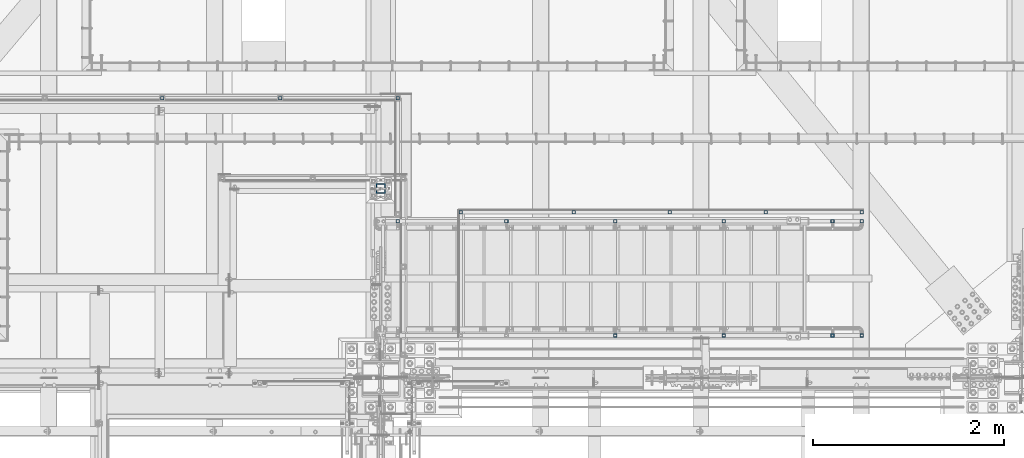
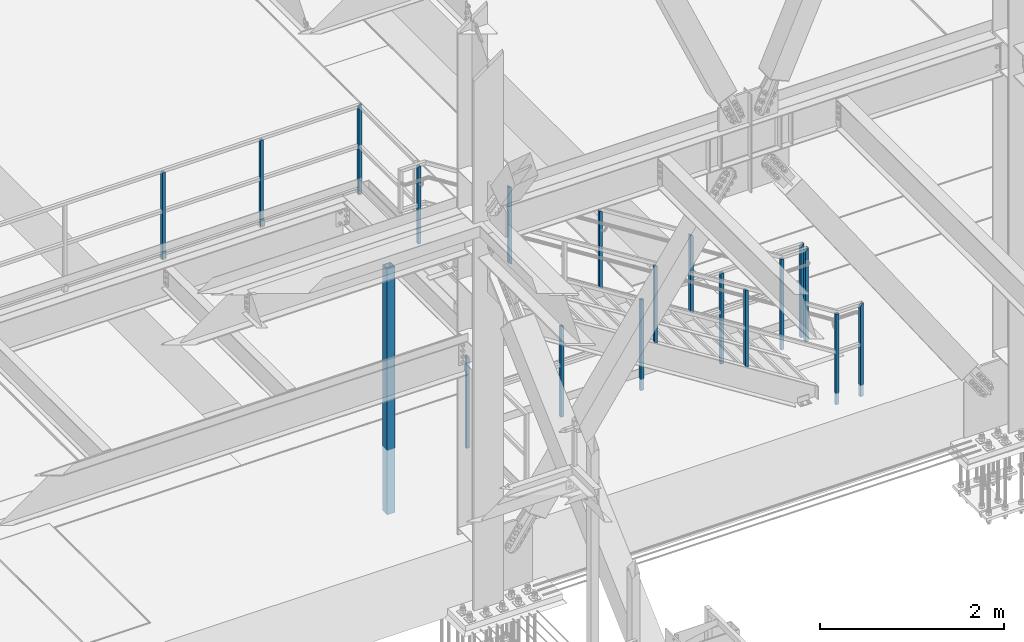
# One storey, part 1310 of 3843: 19 columns, 5 elements without a shape of their own.
"""IFC2X3 building model written with IfcOpenShell, lengths in millimetres."""

import ifcopenshell
import ifcopenshell.guid

model = None  # the IFC model being written
_history = None  # IfcOwnerHistory: only IFC2X3 demands one
_inside = {}  # id of a spatial element -> (the spatial element, [elements in it])
_under = {}  # id of a project, library or spatial element -> (it, [spatial elements below it])
_declared = {}  # id of a project -> (the project, [libraries it declares])
_typed = {}  # id of a type object -> (the type object, [elements of that type])
_made_of = {}  # id of a material, layer set ... -> (it, [elements and type objects made of it])


def new_model(schema):
    """Start an empty IFC model of exactly this schema.

    Asked for "IFC4X3", IfcOpenShell would pick the latest addendum, in which some entities
    have other attributes; the version numbers below select the first issue.
    IFC2X3 requires an IfcOwnerHistory on every rooted entity: one is made here for all.
    """
    global model, _history
    if schema == "IFC4X3":
        model = ifcopenshell.file(schema_version=(4, 3, 0, 0))
    else:
        model = ifcopenshell.file(schema=schema)
    _inside.clear()
    _under.clear()
    _declared.clear()
    _typed.clear()
    _made_of.clear()
    _history = None
    if model.schema == "IFC2X3":
        org = make("IfcOrganization", Name="unknown")
        user = make(
            "IfcPersonAndOrganization",
            ThePerson=make("IfcPerson", FamilyName="unknown"),
            TheOrganization=org,
        )
        app = make(
            "IfcApplication",
            ApplicationDeveloper=org,
            Version="unknown",
            ApplicationFullName="unknown",
            ApplicationIdentifier="unknown",
        )
        _history = make(
            "IfcOwnerHistory",
            OwningUser=user,
            OwningApplication=app,
            ChangeAction="ADDED",
            CreationDate=0,
        )
    return model


def make(cls, **values):
    """One entity of the class cls with the attributes given. An attribute that is None is left unset."""
    return model.create_entity(
        cls, **{name: value for name, value in values.items() if value is not None}
    )


def rooted(cls, **values):
    """An entity with a GlobalId (a new one), such as an element, a storey or a relation."""
    return make(cls, GlobalId=ifcopenshell.guid.new(), OwnerHistory=_history, **values)


def si_unit(unit_type, name, prefix=None):
    """IfcSIUnit, for example si_unit("LENGTHUNIT", "METRE", prefix="MILLI")."""
    return make("IfcSIUnit", UnitType=unit_type, Prefix=prefix, Name=name)


def assignment(units):
    """IfcUnitAssignment: the units of a project."""
    return None if units is None else make("IfcUnitAssignment", Units=units)


def point(xyz):
    """IfcCartesianPoint."""
    return None if xyz is None else make("IfcCartesianPoint", Coordinates=xyz)


def direction(xyz):
    """IfcDirection."""
    return None if xyz is None else make("IfcDirection", DirectionRatios=xyz)


def frame(location, z_axis=None, x_axis=None):
    """IfcAxis2Placement3D, a coordinate frame: its origin and axes. An axis left out is left unset."""
    return make(
        "IfcAxis2Placement3D",
        Location=point(location),
        Axis=direction(z_axis),
        RefDirection=direction(x_axis),
    )


def origin_with_axes():
    """The frame at (0, 0, 0) with the z axis (0, 0, 1) and the x axis (1, 0, 0) written out."""
    return frame((0.0, 0.0, 0.0), z_axis=(0.0, 0.0, 1.0), x_axis=(1.0, 0.0, 0.0))


def place(relative_to, where):
    """IfcLocalPlacement: puts the frame where relative to a parent placement (None: the world)."""
    return make(
        "IfcLocalPlacement", PlacementRelTo=relative_to, RelativePlacement=where
    )


def context(
    kind, dimensions, precision=None, world=None, true_north=None, identifier=None
):
    """IfcGeometricRepresentationContext, for example the 3D "Model" context."""
    return make(
        "IfcGeometricRepresentationContext",
        ContextIdentifier=identifier,
        ContextType=kind,
        CoordinateSpaceDimension=dimensions,
        Precision=precision,
        WorldCoordinateSystem=world,
        TrueNorth=true_north,
    )


def subcontext(parent, identifier, kind, view, scale=None):
    """IfcGeometricRepresentationSubContext, for example "Body" below "Model"."""
    return make(
        "IfcGeometricRepresentationSubContext",
        ContextIdentifier=identifier,
        ContextType=kind,
        ParentContext=parent,
        TargetScale=scale,
        TargetView=view,
    )


def project(units=None, contexts=None):
    """IfcProject with its units and contexts."""
    return rooted(
        "IfcProject",
        Name="project",
        RepresentationContexts=contexts,
        UnitsInContext=assignment(units),
    )


def spatial(cls, under=None, at=None, **own):
    """A site, building, storey or space (cls), placed at a placement, below another one or the project."""
    s = rooted(cls, ObjectPlacement=at, **own)
    if under is not None:
        _under.setdefault(under.id(), (under, []))[1].append(s)
    return s


def faces_of(points, faces, orient=None, outer=None):
    """IfcFace entities. A face is a list of loops; a loop is a list of indices into points, from 0.

    orient and outer hold one flag for each loop. By default every Orientation is true, the
    first loop of a face is its IfcFaceOuterBound and the others are IfcFaceBound.
    """
    made = []
    for i, loops in enumerate(faces):
        bounds = []
        for j, loop in enumerate(loops):
            is_outer = j == 0 if outer is None else outer[i][j]
            bounds.append(
                make(
                    "IfcFaceOuterBound" if is_outer else "IfcFaceBound",
                    Bound=make("IfcPolyLoop", Polygon=[points[k] for k in loop]),
                    Orientation=True if orient is None else orient[i][j],
                )
            )
        made.append(make("IfcFace", Bounds=bounds))
    return made


def faceted_brep(points, faces, orient=None, outer=None, voids=None):
    """IfcFacetedBrep: a solid bounded by flat faces; with voids (closed shells), ...WithVoids."""
    shared = [point(p) for p in points]
    hull = make("IfcClosedShell", CfsFaces=faces_of(shared, faces, orient, outer))
    if voids is None:
        return make("IfcFacetedBrep", Outer=hull)
    return make(
        "IfcFacetedBrepWithVoids",
        Outer=hull,
        Voids=[
            make(cls, CfsFaces=faces_of(shared, fs, o, b)) for cls, fs, o, b in voids
        ],
    )


def shape(context_of_items, identifier, shape_type, items):
    """IfcShapeRepresentation: the items that make up one representation, for example the "Body"."""
    return make(
        "IfcShapeRepresentation",
        ContextOfItems=context_of_items,
        RepresentationIdentifier=identifier,
        RepresentationType=shape_type,
        Items=items,
    )


def material(Name=None, Category=None):
    """IfcMaterial."""
    return make("IfcMaterial", Name=Name, Category=Category)


def made_of(thing, what):
    """Note that an element or type object is made of a material, layer set ...; save() writes the relation."""
    if what is not None:
        _made_of.setdefault(what.id(), (what, []))[1].append(thing)
    return thing


def type_object(cls, material=None, **own):
    """A type object (cls), such as IfcWallType, which elements share."""
    return made_of(rooted(cls, **own), material)


def element(
    cls,
    number,
    at=None,
    inside=None,
    cuts=None,
    type_object=None,
    material=None,
    context=None,
    identifier="Body",
    shape_type=None,
    held_by="IfcProductDefinitionShape",
    body=None,
    shapes=None,
    **own,
):
    """One element of the class cls, such as IfcWall. Its Tag is "e" and its number.

    at: its placement. inside: the storey or other place that contains it. cuts: it is an
    opening in that element (IfcRelVoidsElement). A single representation is given by context,
    identifier, shape_type and body (its items); several are given by shapes. held_by: the class
    of the entity that holds the representations. save() writes the other relations.
    """
    e = rooted(cls, Tag="e%d" % number, ObjectPlacement=at, **own)
    if body is not None:
        shapes = [shape(context, identifier, shape_type, body)]
    if shapes is not None:
        e.Representation = make(held_by, Representations=shapes)
    if inside is not None:
        _inside.setdefault(inside.id(), (inside, []))[1].append(e)
    if cuts is not None:
        rooted(
            "IfcRelVoidsElement", RelatingBuildingElement=cuts, RelatedOpeningElement=e
        )
    if type_object is not None:
        _typed.setdefault(type_object.id(), (type_object, []))[1].append(e)
    return made_of(e, material)


def aggregate(whole, parts):
    """IfcRelAggregates: a whole, such as a stair, and the parts it consists of."""
    return rooted("IfcRelAggregates", RelatingObject=whole, RelatedObjects=parts)


def save(model, path):
    """Write the relations noted so far, then the file.

    IfcRelAggregates (storeys below a building ...), IfcRelContainedInSpatialStructure (elements
    in a storey), IfcRelDefinesByType, IfcRelAssociatesMaterial and IfcRelDeclares: one each for
    every whole, place, type object, material and project.
    """
    for whole, parts in _under.values():
        aggregate(whole, parts)
    for where, things in _inside.values():
        rooted(
            "IfcRelContainedInSpatialStructure",
            RelatedElements=things,
            RelatingStructure=where,
        )
    for kind, things in _typed.values():
        rooted("IfcRelDefinesByType", RelatedObjects=things, RelatingType=kind)
    for what, things in _made_of.values():
        rooted("IfcRelAssociatesMaterial", RelatedObjects=things, RelatingMaterial=what)
    for by, libraries in _declared.values():
        rooted("IfcRelDeclares", RelatingContext=by, RelatedDefinitions=libraries)
    model.write(path)


model = new_model("IFC2X3")

# Units and contexts
model_context = context("Model", 3, precision=1e-05, world=origin_with_axes())
body_context = subcontext(model_context, "Body", "Model", "MODEL_VIEW")
ifc_project = project(units=[si_unit("LENGTHUNIT", "METRE", prefix="MILLI"), si_unit("AREAUNIT", "SQUARE_METRE"), si_unit("VOLUMEUNIT", "CUBIC_METRE"), si_unit("MASSUNIT", "GRAM", prefix="KILO"), si_unit("TIMEUNIT", "SECOND"), si_unit("PLANEANGLEUNIT", "RADIAN"), si_unit("SOLIDANGLEUNIT", "STERADIAN"), si_unit("THERMODYNAMICTEMPERATUREUNIT", "DEGREE_CELSIUS"), si_unit("LUMINOUSINTENSITYUNIT", "LUMEN")], contexts=[model_context])

# Site, building, storey
site_placement = place(None, origin_with_axes())
site = spatial("IfcSite", under=ifc_project, at=site_placement, CompositionType="ELEMENT")
building_placement = place(site_placement, origin_with_axes())
building = spatial("IfcBuilding", under=site, at=building_placement, Name="Undefined", CompositionType="ELEMENT")
storey_placement = place(building_placement, origin_with_axes())
storey = spatial("IfcBuildingStorey", under=building, at=storey_placement, Name="Undefined", CompositionType="ELEMENT", Elevation=0.0)

# Assembly, columns
assembly_1_placement = place(storey_placement, origin_with_axes())
assembly_1 = element("IfcElementAssembly", 1, at=assembly_1_placement, inside=storey, Name="RAIL", AssemblyPlace="NOTDEFINED", PredefinedType="RIGID_FRAME")
ifc_material_1 = material()
column_type_1 = type_object("IfcColumnType", Name="HSS1-1/2X1-1/2X1/4", PredefinedType="NOTDEFINED")
column_1_placement = place(assembly_1_placement, frame((53646.916666621, 28543.25, 33299.4000002631), z_axis=(1.0, 0.0, 0.0), x_axis=(0.0, 0.0, 1.0)))
column_1 = element("IfcColumn", 2, at=column_1_placement, type_object=column_type_1, material=ifc_material_1, Name="POST", ObjectType="HSS1-1/2X1-1/2X1/4", context=body_context, shape_type="Brep", body=[
    faceted_brep([(-88.8999998754371, 12.6999993300014, -12.6999993299978), (-88.8999998754371, -12.6999993300014, -12.6999993299978), (1047.75000076497, -12.6999993300014, -12.6999993299978), (1047.75000076497, 12.6999993300014, -12.6999993299978), (-88.8999998754371, -12.6999993300014, 12.6999993299978), (1047.75000076497, -12.6999993300014, 12.6999993299978), (-88.8999998754371, 12.6999993300014, 12.6999993299978), (1047.75000076497, 12.6999993300014, 12.6999993299978), (-88.8999998754371, 19.0499992350015, -19.0499992350015), (-88.8999998754371, 19.0499992350015, 19.0499992350015), (1047.75000076629, 19.0499992350015, 19.0499992349942), (1047.750000765, 19.0499992350015, -19.0499992350015), (-88.8999998754371, -19.0499992350015, 19.0499992350015), (1047.75000076629, -19.0499992350015, 19.0499992349942), (-88.8999998754371, -19.0499992350015, -19.0499992350015), (1047.750000765, -19.0499992350015, -19.0499992350015)], [[[0, 1, 2, 3]], [[1, 4, 5, 2]], [[4, 6, 7, 5]], [[6, 0, 3, 7]], [[8, 9, 10, 11]], [[9, 12, 13, 10]], [[12, 14, 15, 13]], [[14, 8, 11, 15]], [[13, 15, 11, 10], [5, 7, 3, 2]], [[14, 12, 9, 8], [6, 4, 1, 0]]]),
])
column_2_placement = place(assembly_1_placement, frame((54877.7583332823, 28543.25, 33299.4000002631), z_axis=(1.0, 0.0, 0.0), x_axis=(0.0, 0.0, 1.0)))
column_2 = element("IfcColumn", 3, at=column_2_placement, type_object=column_type_1, material=ifc_material_1, Name="POST", ObjectType="HSS1-1/2X1-1/2X1/4", context=body_context, shape_type="Brep", body=[
    faceted_brep([(-88.8999998754371, 12.6999993300014, -12.6999993299978), (-88.8999998754371, -12.6999993300014, -12.6999993299978), (1047.75000076497, -12.6999993300014, -12.6999993299978), (1047.75000076497, 12.6999993300014, -12.6999993299978), (-88.8999998754371, -12.6999993300014, 12.6999993299978), (1047.75000076497, -12.6999993300014, 12.6999993299978), (-88.8999998754371, 12.6999993300014, 12.6999993299978), (1047.75000076497, 12.6999993300014, 12.6999993299978), (-88.8999998754371, 19.0499992350015, -19.0499992350015), (-88.8999998754371, 19.0499992350015, 19.0499992350015), (1047.75000076629, 19.0499992350015, 19.0499992349942), (1047.750000765, 19.0499992350015, -19.0499992350015), (-88.8999998754371, -19.0499992350015, 19.0499992350015), (1047.75000076629, -19.0499992350015, 19.0499992349942), (-88.8999998754371, -19.0499992350015, -19.0499992350015), (1047.750000765, -19.0499992350015, -19.0499992350015)], [[[0, 1, 2, 3]], [[1, 4, 5, 2]], [[4, 6, 7, 5]], [[6, 0, 3, 7]], [[8, 9, 10, 11]], [[9, 12, 13, 10]], [[12, 14, 15, 13]], [[14, 8, 11, 15]], [[13, 15, 11, 10], [5, 7, 3, 2]], [[14, 12, 9, 8], [6, 4, 1, 0]]]),
])
column_3_placement = place(assembly_1_placement, frame((56108.5999999435, 28543.25, 33299.4000002631), z_axis=(1.0, 0.0, 0.0), x_axis=(0.0, 0.0, 1.0)))
column_3 = element("IfcColumn", 4, at=column_3_placement, type_object=column_type_1, material=ifc_material_1, Name="POST", ObjectType="HSS1-1/2X1-1/2X1/4", context=body_context, shape_type="Brep", body=[
    faceted_brep([(-88.8999998754371, 12.6999993300014, -12.6999993299978), (-88.8999998754371, -12.6999993300014, -12.6999993299978), (1054.10000067001, -12.6999993300014, -12.6999993299978), (1054.10000067001, 12.6999993300014, -12.6999993299978), (-88.8999998754371, -12.6999993300014, 12.6999993299978), (1079.49999933, -12.6999993300014, 12.6999993299978), (-88.8999998754371, 12.6999993300014, 12.6999993299978), (1079.49999933, 12.6999993300014, 12.6999993299978), (-88.8999998754371, 19.0499992350015, -19.0499992350015), (-88.8999998754371, 19.0499992350015, 19.0499992350015), (1085.849999235, 19.0499992350015, 19.0499992350015), (1047.750000765, 19.0499992350015, -19.0499992350015), (-88.8999998754371, -19.0499992350015, 19.0499992350015), (1085.849999235, -19.0499992350015, 19.0499992350015), (-88.8999998754371, -19.0499992350015, -19.0499992350015), (1047.750000765, -19.0499992350015, -19.0499992350015)], [[[0, 1, 2, 3]], [[1, 4, 5, 2]], [[4, 6, 7, 5]], [[6, 0, 3, 7]], [[8, 9, 10, 11]], [[9, 12, 13, 10]], [[12, 14, 15, 13]], [[14, 8, 11, 15]], [[13, 15, 11, 10], [5, 7, 3, 2]], [[14, 12, 9, 8], [6, 4, 1, 0]]]),
])
aggregate(assembly_1, [column_1, column_2, column_3])

assembly_2_placement = place(storey_placement, origin_with_axes())
assembly_2 = element("IfcElementAssembly", 5, at=assembly_2_placement, inside=storey, Name="RAIL", AssemblyPlace="NOTDEFINED", PredefinedType="RIGID_FRAME")
column_4_placement = place(assembly_2_placement, frame((59956.6999999969, 27349.45000005, 30479.9999999739), z_axis=(1.0, 0.0, 0.0), x_axis=(0.0, 0.0, 1.0)))
column_4 = element("IfcColumn", 6, at=column_4_placement, type_object=column_type_1, material=ifc_material_1, Name="POST", ObjectType="HSS1-1/2X1-1/2X1/4", context=body_context, shape_type="Brep", body=[
    faceted_brep([(-152.399999977541, 12.6999993299978, -12.6999993299978), (-152.399999977541, -12.6999993299978, -12.6999993299978), (1047.75000076497, -12.6999993300014, -12.6999993299978), (1047.75000076497, 12.6999993300014, -12.6999993299978), (-152.399999977541, -12.6999993299978, 12.6999993299978), (1047.75000076497, -12.6999993300014, 12.6999993299978), (-152.399999977541, 12.6999993299978, 12.6999993299978), (1047.75000076497, 12.6999993300014, 12.6999993299978), (-152.399999977541, 19.0499992350015, -19.0499992349942), (-152.399999977541, 19.0499992350015, 19.0499992349942), (1047.75000076629, 19.0499992350015, 19.0499992349942), (1047.750000765, 19.0499992350015, -19.0499992350015), (-152.399999977541, -19.0499992350015, 19.0499992349942), (1047.75000076629, -19.0499992350015, 19.0499992349942), (-152.399999977541, -19.0499992350015, -19.0499992349942), (1047.750000765, -19.0499992350015, -19.0499992350015)], [[[0, 1, 2, 3]], [[1, 4, 5, 2]], [[4, 6, 7, 5]], [[6, 0, 3, 7]], [[8, 9, 10, 11]], [[9, 12, 13, 10]], [[12, 14, 15, 13]], [[14, 8, 11, 15]], [[13, 15, 11, 10], [5, 7, 3, 2]], [[14, 12, 9, 8], [6, 4, 1, 0]]]),
])
column_5_placement = place(assembly_2_placement, frame((57950.1000000012, 27349.45000005, 30479.9999999739), z_axis=(1.0, 0.0, 0.0), x_axis=(0.0, 0.0, 1.0)))
column_5 = element("IfcColumn", 7, at=column_5_placement, type_object=column_type_1, material=ifc_material_1, Name="POST", ObjectType="HSS1-1/2X1-1/2X1/4", context=body_context, shape_type="Brep", body=[
    faceted_brep([(-152.399999977541, 12.6999993299978, -12.6999993299978), (-152.399999977541, -12.6999993299978, -12.6999993299978), (1047.75000076497, -12.6999993300014, -12.6999993299978), (1047.75000076497, 12.6999993300014, -12.6999993299978), (-152.399999977541, -12.6999993299978, 12.6999993299978), (1047.75000076497, -12.6999993300014, 12.6999993299978), (-152.399999977541, 12.6999993299978, 12.6999993299978), (1047.75000076497, 12.6999993300014, 12.6999993299978), (-152.399999977541, 19.0499992350015, -19.0499992349942), (-152.399999977541, 19.0499992350015, 19.0499992349942), (1047.75000076629, 19.0499992350015, 19.0499992349942), (1047.750000765, 19.0499992350015, -19.0499992350015), (-152.399999977541, -19.0499992350015, 19.0499992349942), (1047.75000076629, -19.0499992350015, 19.0499992349942), (-152.399999977541, -19.0499992350015, -19.0499992349942), (1047.750000765, -19.0499992350015, -19.0499992350015)], [[[0, 1, 2, 3]], [[1, 4, 5, 2]], [[4, 6, 7, 5]], [[6, 0, 3, 7]], [[8, 9, 10, 11]], [[9, 12, 13, 10]], [[12, 14, 15, 13]], [[14, 8, 11, 15]], [[13, 15, 11, 10], [5, 7, 3, 2]], [[14, 12, 9, 8], [6, 4, 1, 0]]]),
])
column_6_placement = place(assembly_2_placement, frame((58953.399999999, 27349.45000005, 30479.9999999739), z_axis=(1.0, 0.0, 0.0), x_axis=(0.0, 0.0, 1.0)))
column_6 = element("IfcColumn", 8, at=column_6_placement, type_object=column_type_1, material=ifc_material_1, Name="POST", ObjectType="HSS1-1/2X1-1/2X1/4", context=body_context, shape_type="Brep", body=[
    faceted_brep([(-152.399999977541, 12.6999993299978, -12.6999993299978), (-152.399999977541, -12.6999993299978, -12.6999993299978), (1047.75000076497, -12.6999993300014, -12.6999993299978), (1047.75000076497, 12.6999993300014, -12.6999993299978), (-152.399999977541, -12.6999993299978, 12.6999993299978), (1047.75000076497, -12.6999993300014, 12.6999993299978), (-152.399999977541, 12.6999993299978, 12.6999993299978), (1047.75000076497, 12.6999993300014, 12.6999993299978), (-152.399999977541, 19.0499992350015, -19.0499992349942), (-152.399999977541, 19.0499992350015, 19.0499992349942), (1047.75000076629, 19.0499992350015, 19.0499992349942), (1047.750000765, 19.0499992350015, -19.0499992350015), (-152.399999977541, -19.0499992350015, 19.0499992349942), (1047.75000076629, -19.0499992350015, 19.0499992349942), (-152.399999977541, -19.0499992350015, -19.0499992349942), (1047.750000765, -19.0499992350015, -19.0499992350015)], [[[0, 1, 2, 3]], [[1, 4, 5, 2]], [[4, 6, 7, 5]], [[6, 0, 3, 7]], [[8, 9, 10, 11]], [[9, 12, 13, 10]], [[12, 14, 15, 13]], [[14, 8, 11, 15]], [[13, 15, 11, 10], [5, 7, 3, 2]], [[14, 12, 9, 8], [6, 4, 1, 0]]]),
])
column_7_placement = place(assembly_2_placement, frame((56769.0000000085, 27349.45000005, 30479.9999999739), z_axis=(1.0, 0.0, 0.0), x_axis=(0.0, 0.0, 1.0)))
column_7 = element("IfcColumn", 9, at=column_7_placement, type_object=column_type_1, material=ifc_material_1, Name="POST", ObjectType="HSS1-1/2X1-1/2X1/4", context=body_context, shape_type="Brep", body=[
    faceted_brep([(-152.399999977541, 12.6999993299978, -12.6999993299978), (-152.399999977541, -12.6999993299978, -12.6999993299978), (1079.49999933128, -12.6999993300014, -12.6999993299978), (1079.49999933128, 12.6999993300014, -12.6999993299978), (-152.399999977541, -12.6999993299978, 12.6999993299978), (1054.10000067129, -12.6999993300014, 12.6999993299978), (-152.399999977541, 12.6999993299978, 12.6999993299978), (1054.10000067129, 12.6999993300014, 12.6999993299978), (-152.399999977541, 19.0499992350015, -19.0499992349942), (-152.399999977541, 19.0499992350015, 19.0499992349942), (1047.75000076629, 19.0499992350015, 19.0499992349942), (1085.84999923629, 19.0499992350015, -19.0499992349942), (-152.399999977541, -19.0499992350015, 19.0499992349942), (1047.75000076629, -19.0499992350015, 19.0499992349942), (-152.399999977541, -19.0499992350015, -19.0499992349942), (1085.84999923629, -19.0499992350015, -19.0499992349942)], [[[0, 1, 2, 3]], [[1, 4, 5, 2]], [[4, 6, 7, 5]], [[6, 0, 3, 7]], [[8, 9, 10, 11]], [[9, 12, 13, 10]], [[12, 14, 15, 13]], [[14, 8, 11, 15]], [[13, 15, 11, 10], [5, 7, 3, 2]], [[14, 12, 9, 8], [6, 4, 1, 0]]]),
])
column_8_placement = place(assembly_2_placement, frame((60959.9999999948, 27349.45000005, 30479.9999999739), z_axis=(1.0, 0.0, 0.0), x_axis=(0.0, 0.0, 1.0)))
column_8 = element("IfcColumn", 10, at=column_8_placement, type_object=column_type_1, material=ifc_material_1, Name="POST", ObjectType="HSS1-1/2X1-1/2X1/4", context=body_context, shape_type="Brep", body=[
    faceted_brep([(-152.399999977541, 12.6999993299978, -12.6999993299978), (-152.399999977541, -12.6999993299978, -12.6999993299978), (1054.10000067001, -12.6999993300014, -12.6999993299978), (1054.10000067001, 12.6999993300014, -12.6999993299978), (-152.399999977541, -12.6999993299978, 12.6999993299978), (1079.49999933, -12.6999993300014, 12.6999993299978), (-152.399999977541, 12.6999993299978, 12.6999993299978), (1079.49999933, 12.6999993300014, 12.6999993299978), (-152.399999977541, 19.0499992350015, -19.0499992349942), (-152.399999977541, 19.0499992350015, 19.0499992349942), (1085.849999235, 19.0499992350015, 19.0499992350015), (1047.750000765, 19.0499992350015, -19.0499992350015), (-152.399999977541, -19.0499992350015, 19.0499992349942), (1085.849999235, -19.0499992350015, 19.0499992350015), (-152.399999977541, -19.0499992350015, -19.0499992349942), (1047.750000765, -19.0499992350015, -19.0499992350015)], [[[0, 1, 2, 3]], [[1, 4, 5, 2]], [[4, 6, 7, 5]], [[6, 0, 3, 7]], [[8, 9, 10, 11]], [[9, 12, 13, 10]], [[12, 14, 15, 13]], [[14, 8, 11, 15]], [[13, 15, 11, 10], [5, 7, 3, 2]], [[14, 12, 9, 8], [6, 4, 1, 0]]]),
])
aggregate(assembly_2, [column_4, column_5, column_6, column_7, column_8])

assembly_3_placement = place(storey_placement, origin_with_axes())
assembly_3 = element("IfcElementAssembly", 11, at=assembly_3_placement, inside=storey, Name="RAIL", AssemblyPlace="NOTDEFINED", PredefinedType="RIGID_FRAME")
column_9_placement = place(assembly_3_placement, frame((56108.5999999435, 27254.20000005, 33299.4000002631), z_axis=(1.0, 0.0, 0.0), x_axis=(0.0, 0.0, 1.0)))
column_9 = element("IfcColumn", 12, at=column_9_placement, type_object=column_type_1, material=ifc_material_1, Name="POST", ObjectType="HSS1-1/2X1-1/2X1/4", context=body_context, shape_type="Brep", body=[
    faceted_brep([(1047.75000076629, -19.0499992350015, 19.0499992349942), (1047.750000765, -19.0499992350015, -19.0499992350015), (1047.750000765, 19.0499992350015, -19.0499992350015), (1047.75000076629, 19.0499992350015, 19.0499992349942), (1047.75000076497, -12.6999993300014, 12.6999993299978), (1047.75000076497, 12.6999993300014, 12.6999993299978), (1047.75000076497, 12.6999993300014, -12.6999993299978), (1047.75000076497, -12.6999993300014, -12.6999993299978), (25.4000000135893, 19.0499992350015, -19.0499992349942), (25.4000000135893, 19.0499992350015, 19.0499992349942), (25.4000000135893, -19.0499992350015, -19.0499992349942), (25.4000000135893, -19.0499992350015, 19.0499992349942), (25.4000000135893, 12.6999993300014, -12.6999993299978), (25.4000000135893, 12.6999993300014, 12.6999993299978), (25.4000000135893, -12.6999993300014, 12.6999993299978), (25.4000000135893, -12.6999993300014, -12.6999993299978)], [[[0, 1, 2, 3], [4, 5, 6, 7]], [[3, 2, 8, 9]], [[2, 1, 10, 8]], [[1, 0, 11, 10]], [[0, 3, 9, 11]], [[8, 10, 11, 9], [12, 13, 14, 15]], [[4, 7, 15, 14]], [[7, 6, 12, 15]], [[6, 5, 13, 12]], [[5, 4, 14, 13]]]),
])
column_10_placement = place(assembly_3_placement, frame((57245.2499999552, 27254.20000005, 32660.6230938254), z_axis=(1.0, 0.0, 0.0), x_axis=(0.0, 0.0, 1.0)))
column_10 = element("IfcColumn", 13, at=column_10_placement, type_object=column_type_1, material=ifc_material_1, Name="POST", ObjectType="HSS1-1/2X1-1/2X1/4", context=body_context, shape_type="Brep", body=[
    faceted_brep([(8.00965862412704, 12.6999993300014, -12.6999993299978), (8.00965862412704, -12.6999993300014, -12.6999993299978), (1022.25781065416, -12.6999993300014, -12.6999993299978), (1022.25781065416, 12.6999993300014, -12.6999993299978), (-8.00965871479639, -12.6999993300014, 12.6999993299978), (1006.23849331524, -12.6999993300014, 12.6999993299978), (-8.00965871479639, 12.6999993300014, 12.6999993299978), (1006.23849331524, 12.6999993300014, 12.6999993299978), (12.0144881102206, 19.0499992350015, -19.0499992350015), (-12.0144882008899, 19.0499992350015, 19.0499992350015), (1002.23366382914, 19.0499992350015, 19.0499992350015), (1026.26264014026, 19.0499992350015, -19.0499992350015), (-12.0144882008899, -19.0499992350015, 19.0499992350015), (1002.23366382914, -19.0499992350015, 19.0499992350015), (12.0144881102206, -19.0499992350015, -19.0499992350015), (1026.26264014026, -19.0499992350015, -19.0499992350015)], [[[0, 1, 2, 3]], [[1, 4, 5, 2]], [[4, 6, 7, 5]], [[6, 0, 3, 7]], [[8, 9, 10, 11]], [[9, 12, 13, 10]], [[12, 14, 15, 13]], [[14, 8, 11, 15]], [[13, 15, 11, 10], [5, 7, 3, 2]], [[14, 12, 9, 8], [6, 4, 1, 0]]]),
])
column_11_placement = place(assembly_3_placement, frame((58381.8999999682, 27254.20000005, 31943.7586050649), z_axis=(1.0, 0.0, 0.0), x_axis=(0.0, 0.0, 1.0)))
column_11 = element("IfcColumn", 14, at=column_11_placement, type_object=column_type_1, material=ifc_material_1, Name="POST", ObjectType="HSS1-1/2X1-1/2X1/4", context=body_context, shape_type="Brep", body=[
    faceted_brep([(8.00965862412704, 12.6999993300014, -12.6999993299978), (8.00965862412704, -12.6999993300014, -12.6999993299978), (1022.25781065416, -12.6999993300014, -12.6999993299978), (1022.25781065416, 12.6999993300014, -12.6999993299978), (-8.00965871479639, -12.6999993300014, 12.6999993299978), (1006.23849331524, -12.6999993300014, 12.6999993299978), (-8.00965871479639, 12.6999993300014, 12.6999993299978), (1006.23849331524, 12.6999993300014, 12.6999993299978), (12.0144881102206, 19.0499992350015, -19.0499992350015), (-12.0144882008899, 19.0499992350015, 19.0499992350015), (1002.23366382914, 19.0499992350015, 19.0499992350015), (1026.26264014026, 19.0499992350015, -19.0499992350015), (-12.0144882008899, -19.0499992350015, 19.0499992350015), (1002.23366382914, -19.0499992350015, 19.0499992350015), (12.0144881102206, -19.0499992350015, -19.0499992350015), (1026.26264014026, -19.0499992350015, -19.0499992350015)], [[[0, 1, 2, 3]], [[1, 4, 5, 2]], [[4, 6, 7, 5]], [[6, 0, 3, 7]], [[8, 9, 10, 11]], [[9, 12, 13, 10]], [[12, 14, 15, 13]], [[14, 8, 11, 15]], [[13, 15, 11, 10], [5, 7, 3, 2]], [[14, 12, 9, 8], [6, 4, 1, 0]]]),
])
column_12_placement = place(assembly_3_placement, frame((59518.5499999813, 27254.20000005, 31226.8941163045), z_axis=(1.0, 0.0, 0.0), x_axis=(0.0, 0.0, 1.0)))
column_12 = element("IfcColumn", 15, at=column_12_placement, type_object=column_type_1, material=ifc_material_1, Name="POST", ObjectType="HSS1-1/2X1-1/2X1/4", context=body_context, shape_type="Brep", body=[
    faceted_brep([(8.00965862412704, 12.6999993300014, -12.6999993299978), (8.00965862412704, -12.6999993300014, -12.6999993299978), (1022.25781065416, -12.6999993300014, -12.6999993299978), (1022.25781065416, 12.6999993300014, -12.6999993299978), (-8.00965871479639, -12.6999993300014, 12.6999993299978), (1006.23849331524, -12.6999993300014, 12.6999993299978), (-8.00965871479639, 12.6999993300014, 12.6999993299978), (1006.23849331524, 12.6999993300014, 12.6999993299978), (12.0144881102206, 19.0499992350015, -19.0499992350015), (-12.0144882008899, 19.0499992350015, 19.0499992350015), (1002.23366382914, 19.0499992350015, 19.0499992350015), (1026.26264014026, 19.0499992350015, -19.0499992350015), (-12.0144882008899, -19.0499992350015, 19.0499992350015), (1002.23366382914, -19.0499992350015, 19.0499992350015), (12.0144881102206, -19.0499992350015, -19.0499992350015), (1026.26264014026, -19.0499992350015, -19.0499992350015)], [[[0, 1, 2, 3]], [[1, 4, 5, 2]], [[4, 6, 7, 5]], [[6, 0, 3, 7]], [[8, 9, 10, 11]], [[9, 12, 13, 10]], [[12, 14, 15, 13]], [[14, 8, 11, 15]], [[13, 15, 11, 10], [5, 7, 3, 2]], [[14, 12, 9, 8], [6, 4, 1, 0]]]),
])
column_13_placement = place(assembly_3_placement, frame((60655.1999999948, 27254.20000005, 30479.9999999806), z_axis=(1.0, 0.0, 0.0), x_axis=(0.0, 0.0, 1.0)))
column_13 = element("IfcColumn", 16, at=column_13_placement, type_object=column_type_1, material=ifc_material_1, Name="POST", ObjectType="HSS1-1/2X1-1/2X1/4", context=body_context, shape_type="Brep", body=[
    faceted_brep([(1047.75000076629, -19.0499992350015, 19.0499992349942), (1047.7500007748, -19.0499992349978, -5.50550330031547), (1047.7500007748, -12.6999993300014, -5.50550330031547), (1047.75000076497, -12.6999993300014, 12.6999993299978), (1047.75000076497, 12.6999993300014, 12.6999993299978), (1047.7500007748, 12.6999993300014, -5.50550330031547), (1047.7500007748, 19.0499992350015, -5.50550330031547), (1047.75000076629, 19.0499992350015, 19.0499992349942), (1056.29226809751, -19.0499992350015, -19.0499992350015), (1056.29226809751, 19.0499992350015, -19.0499992350015), (1052.28743861182, 12.6999993300014, -12.6999993299978), (1052.28743861182, -12.6999993300014, -12.6999993299978), (-152.399999977541, 19.0499992350015, 19.0499992349942), (-152.399999977541, -19.0499992350015, 19.0499992349942), (-152.399999977541, -19.0499992350015, -19.0499992349942), (-152.399999977541, 19.0499992350015, -19.0499992349942), (-152.399999977541, 12.6999993299978, 12.6999993299978), (-152.399999977541, -12.6999993299978, 12.6999993299978), (-152.399999977541, -12.6999993299978, -12.6999993299978), (-152.399999977541, 12.6999993299978, -12.6999993299978)], [[[0, 1, 2, 3, 4, 5, 6, 7]], [[8, 9, 6, 5, 10, 11, 2, 1]], [[12, 13, 0, 7]], [[0, 13, 14, 8, 1]], [[14, 15, 9, 8]], [[15, 12, 7, 6, 9]], [[14, 13, 12, 15], [16, 17, 18, 19]], [[19, 18, 11, 10]], [[4, 16, 19, 10, 5]], [[17, 16, 4, 3]], [[18, 17, 3, 2, 11]]]),
])
column_14_placement = place(assembly_3_placement, frame((60959.9999999948, 27254.20000005, 30479.9999999739), z_axis=(1.0, 0.0, 0.0), x_axis=(0.0, 0.0, 1.0)))
column_14 = element("IfcColumn", 17, at=column_14_placement, type_object=column_type_1, material=ifc_material_1, Name="POST", ObjectType="HSS1-1/2X1-1/2X1/4", context=body_context, shape_type="Brep", body=[
    faceted_brep([(-152.399999977541, 12.6999993299978, -12.6999993299978), (-152.399999977541, -12.6999993299978, -12.6999993299978), (1054.10000067001, -12.6999993300014, -12.6999993299978), (1054.10000067001, 12.6999993300014, -12.6999993299978), (-152.399999977541, -12.6999993299978, 12.6999993299978), (1079.49999933, -12.6999993300014, 12.6999993299978), (-152.399999977541, 12.6999993299978, 12.6999993299978), (1079.49999933, 12.6999993300014, 12.6999993299978), (-152.399999977541, 19.0499992350015, -19.0499992349942), (-152.399999977541, 19.0499992350015, 19.0499992349942), (1085.849999235, 19.0499992350015, 19.0499992350015), (1047.750000765, 19.0499992350015, -19.0499992350015), (-152.399999977541, -19.0499992350015, 19.0499992349942), (1085.849999235, -19.0499992350015, 19.0499992350015), (-152.399999977541, -19.0499992350015, -19.0499992349942), (1047.750000765, -19.0499992350015, -19.0499992350015)], [[[0, 1, 2, 3]], [[1, 4, 5, 2]], [[4, 6, 7, 5]], [[6, 0, 3, 7]], [[8, 9, 10, 11]], [[9, 12, 13, 10]], [[12, 14, 15, 13]], [[14, 8, 11, 15]], [[13, 15, 11, 10], [5, 7, 3, 2]], [[14, 12, 9, 8], [6, 4, 1, 0]]]),
])
aggregate(assembly_3, [column_9, column_10, column_11, column_12, column_13, column_14])

assembly_4_placement = place(storey_placement, origin_with_axes())
assembly_4 = element("IfcElementAssembly", 18, at=assembly_4_placement, inside=storey, Name="RAIL", AssemblyPlace="NOTDEFINED", PredefinedType="RIGID_FRAME")
column_15_placement = place(assembly_4_placement, frame((58381.8999999634, 26060.40000005, 31943.7586050722), z_axis=(1.0, 0.0, 0.0), x_axis=(0.0, 0.0, 1.0)))
column_15 = element("IfcColumn", 19, at=column_15_placement, type_object=column_type_1, material=ifc_material_1, Name="POST", ObjectType="HSS1-1/2X1-1/2X1/4", context=body_context, shape_type="Brep", body=[
    faceted_brep([(8.00965862412704, 12.6999993300014, -12.6999993299978), (8.00965862412704, -12.6999993300014, -12.6999993299978), (1022.25781065416, -12.6999993300014, -12.6999993299978), (1022.25781065416, 12.6999993300014, -12.6999993299978), (-8.00965871479639, -12.6999993300014, 12.6999993299978), (1006.23849331524, -12.6999993300014, 12.6999993299978), (-8.00965871479639, 12.6999993300014, 12.6999993299978), (1006.23849331524, 12.6999993300014, 12.6999993299978), (12.0144881102206, 19.0499992350015, -19.0499992350015), (-12.0144882008899, 19.0499992350015, 19.0499992350015), (1002.23366382914, 19.0499992350015, 19.0499992350015), (1026.26264014026, 19.0499992350015, -19.0499992350015), (-12.0144882008899, -19.0499992350015, 19.0499992350015), (1002.23366382914, -19.0499992350015, 19.0499992350015), (12.0144881102206, -19.0499992350015, -19.0499992350015), (1026.26264014026, -19.0499992350015, -19.0499992350015)], [[[0, 1, 2, 3]], [[1, 4, 5, 2]], [[4, 6, 7, 5]], [[6, 0, 3, 7]], [[8, 9, 10, 11]], [[9, 12, 13, 10]], [[12, 14, 15, 13]], [[14, 8, 11, 15]], [[13, 15, 11, 10], [5, 7, 3, 2]], [[14, 12, 9, 8], [6, 4, 1, 0]]]),
])
column_16_placement = place(assembly_4_placement, frame((59518.5499999791, 26060.40000005, 31226.8941163076), z_axis=(1.0, 0.0, 0.0), x_axis=(0.0, 0.0, 1.0)))
column_16 = element("IfcColumn", 20, at=column_16_placement, type_object=column_type_1, material=ifc_material_1, Name="POST", ObjectType="HSS1-1/2X1-1/2X1/4", context=body_context, shape_type="Brep", body=[
    faceted_brep([(8.00965862412704, 12.6999993300014, -12.6999993299978), (8.00965862412704, -12.6999993300014, -12.6999993299978), (1022.25781065416, -12.6999993300014, -12.6999993299978), (1022.25781065416, 12.6999993300014, -12.6999993299978), (-8.00965871479639, -12.6999993300014, 12.6999993299978), (1006.23849331524, -12.6999993300014, 12.6999993299978), (-8.00965871479639, 12.6999993300014, 12.6999993299978), (1006.23849331524, 12.6999993300014, 12.6999993299978), (12.0144881102206, 19.0499992350015, -19.0499992350015), (-12.0144882008899, 19.0499992350015, 19.0499992350015), (1002.23366382914, 19.0499992350015, 19.0499992350015), (1026.26264014026, 19.0499992350015, -19.0499992350015), (-12.0144882008899, -19.0499992350015, 19.0499992350015), (1002.23366382914, -19.0499992350015, 19.0499992350015), (12.0144881102206, -19.0499992350015, -19.0499992350015), (1026.26264014026, -19.0499992350015, -19.0499992350015)], [[[0, 1, 2, 3]], [[1, 4, 5, 2]], [[4, 6, 7, 5]], [[6, 0, 3, 7]], [[8, 9, 10, 11]], [[9, 12, 13, 10]], [[12, 14, 15, 13]], [[14, 8, 11, 15]], [[13, 15, 11, 10], [5, 7, 3, 2]], [[14, 12, 9, 8], [6, 4, 1, 0]]]),
])
column_17_placement = place(assembly_4_placement, frame((60655.1999999967, 26060.40000005, 30479.9999999775), z_axis=(1.0, 0.0, 0.0), x_axis=(0.0, 0.0, 1.0)))
column_17 = element("IfcColumn", 21, at=column_17_placement, type_object=column_type_1, material=ifc_material_1, Name="POST", ObjectType="HSS1-1/2X1-1/2X1/4", context=body_context, shape_type="Brep", body=[
    faceted_brep([(1047.75000076629, -19.0499992350015, 19.0499992349942), (1047.7500007748, -19.0499992349978, -5.50550330031547), (1047.7500007748, -12.6999993300014, -5.50550330031547), (1047.75000076497, -12.6999993300014, 12.6999993299978), (1047.75000076497, 12.6999993300014, 12.6999993299978), (1047.7500007748, 12.6999993300014, -5.50550330031547), (1047.7500007748, 19.0499992350015, -5.50550330031547), (1047.75000076629, 19.0499992350015, 19.0499992349942), (1056.29226809751, -19.0499992350015, -19.0499992350015), (1056.29226809751, 19.0499992350015, -19.0499992350015), (1052.28743861182, 12.6999993300014, -12.6999993299978), (1052.28743861182, -12.6999993300014, -12.6999993299978), (-152.399999977541, 19.0499992350015, 19.0499992349942), (-152.399999977541, -19.0499992350015, 19.0499992349942), (-152.399999977541, -19.0499992350015, -19.0499992349942), (-152.399999977541, 19.0499992350015, -19.0499992349942), (-152.399999977541, 12.6999993299978, 12.6999993299978), (-152.399999977541, -12.6999993299978, 12.6999993299978), (-152.399999977541, -12.6999993299978, -12.6999993299978), (-152.399999977541, 12.6999993299978, -12.6999993299978)], [[[0, 1, 2, 3, 4, 5, 6, 7]], [[8, 9, 6, 5, 10, 11, 2, 1]], [[12, 13, 0, 7]], [[0, 13, 14, 8, 1]], [[14, 15, 9, 8]], [[15, 12, 7, 6, 9]], [[14, 13, 12, 15], [16, 17, 18, 19]], [[19, 18, 11, 10]], [[4, 16, 19, 10, 5]], [[17, 16, 4, 3]], [[18, 17, 3, 2, 11]]]),
])
column_18_placement = place(assembly_4_placement, frame((60959.9999999967, 26060.40000005, 30479.9999999676), z_axis=(1.0, 0.0, 0.0), x_axis=(0.0, 0.0, 1.0)))
column_18 = element("IfcColumn", 22, at=column_18_placement, type_object=column_type_1, material=ifc_material_1, Name="POST", ObjectType="HSS1-1/2X1-1/2X1/4", context=body_context, shape_type="Brep", body=[
    faceted_brep([(-152.399999977541, 12.6999993299978, -12.6999993299978), (-152.399999977541, -12.6999993299978, -12.6999993299978), (1054.10000067001, -12.6999993300014, -12.6999993299978), (1054.10000067001, 12.6999993300014, -12.6999993299978), (-152.399999977541, -12.6999993299978, 12.6999993299978), (1079.49999933, -12.6999993300014, 12.6999993299978), (-152.399999977541, 12.6999993299978, 12.6999993299978), (1079.49999933, 12.6999993300014, 12.6999993299978), (-152.399999977541, 19.0499992350015, -19.0499992349942), (-152.399999977541, 19.0499992350015, 19.0499992349942), (1085.849999235, 19.0499992350015, 19.0499992350015), (1047.750000765, 19.0499992350015, -19.0499992350015), (-152.399999977541, -19.0499992350015, 19.0499992349942), (1085.849999235, -19.0499992350015, 19.0499992350015), (-152.399999977541, -19.0499992350015, -19.0499992349942), (1047.750000765, -19.0499992350015, -19.0499992350015)], [[[0, 1, 2, 3]], [[1, 4, 5, 2]], [[4, 6, 7, 5]], [[6, 0, 3, 7]], [[8, 9, 10, 11]], [[9, 12, 13, 10]], [[12, 14, 15, 13]], [[14, 8, 11, 15]], [[13, 15, 11, 10], [5, 7, 3, 2]], [[14, 12, 9, 8], [6, 4, 1, 0]]]),
])
aggregate(assembly_4, [column_15, column_16, column_17, column_18])

# Assembly, column
assembly_5_placement = place(storey_placement, origin_with_axes())
assembly_5 = element("IfcElementAssembly", 23, at=assembly_5_placement, inside=storey, Name="COLUMN", AssemblyPlace="NOTDEFINED", PredefinedType="RIGID_FRAME")
ifc_material_2 = material()
column_type_2 = type_object("IfcColumnType", Name="HSS4X4X3/8", PredefinedType="NOTDEFINED")
column_19_placement = place(assembly_5_placement, frame((55930.8, 27597.1, 29565.6), z_axis=(-1.0, 0.0, 0.0), x_axis=(0.0, 0.0, 1.0)))
column_19 = element("IfcColumn", 24, at=column_19_placement, type_object=column_type_2, material=ifc_material_2, Name="COLUMN", ObjectType="HSS4X4X3/8", context=body_context, shape_type="Brep", body=[
    faceted_brep([(57.1500000000015, 41.2749999999942, -41.2750000000015), (57.1500000000015, -41.2749999999942, -41.2750000000015), (3314.69999999951, -41.2750000000015, -41.2750000000015), (3314.69999999951, 41.2750000000015, -41.2750000000015), (57.1500000000015, -41.2749999999942, 41.2750000000015), (3314.69999999951, -41.2750000000015, 41.2750000000015), (57.1500000000015, 41.2749999999942, 41.2750000000015), (3314.69999999951, 41.2750000000015, 41.2750000000015), (57.1500000000015, 50.8000000000029, -50.8000000000029), (57.1500000000015, 50.8000000000029, 50.8000000000029), (3314.69999999951, 50.7999999999993, 50.8000000000029), (3314.69999999951, 50.7999999999993, -50.8000000000029), (57.1500000000015, -50.8000000000029, 50.8000000000029), (3314.69999999951, -50.7999999999993, 50.8000000000029), (57.1500000000015, -50.8000000000029, -50.8000000000029), (3314.69999999951, -50.7999999999993, -50.8000000000029)], [[[0, 1, 2, 3]], [[1, 4, 5, 2]], [[4, 6, 7, 5]], [[6, 0, 3, 7]], [[8, 9, 10, 11]], [[9, 12, 13, 10]], [[12, 14, 15, 13]], [[14, 8, 11, 15]], [[13, 15, 11, 10], [5, 7, 3, 2]], [[14, 12, 9, 8], [6, 4, 1, 0]]]),
])
aggregate(assembly_5, [column_19])

save(model, "model.ifc")
